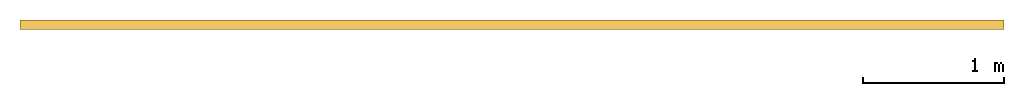
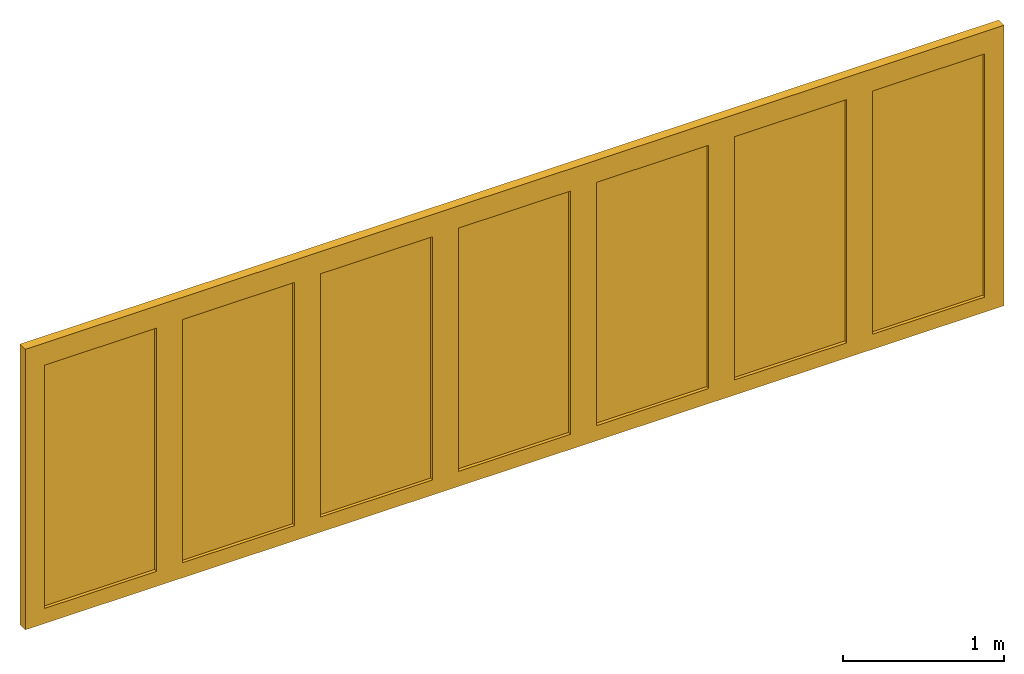
# One storey: 1 door.
"""IFC2X3 building model written with IfcOpenShell, lengths in millimetres."""

from ifc_helpers import new_model, entity, si_unit, converted_unit, direction, frame, frame_2d, origin, origin_2d_with_axis, place, context, subcontext, project, spatial, polyline, rectangle, outline, extrude, source, transform, mapped, material, material_list, type_object, type_shapes, element, save


model = new_model("IFC2X3")

# Units and contexts
model_context = context("Model", 3, precision=1e-06, world=origin(), true_north=direction((2.0, -1.71512652170913e-15, 1.0)))
context_of_model = context(None, 3, precision=1e-06, world=origin(), true_north=direction((2.0, -1.71512652170913e-15, 1.0)))
body_context = subcontext(model_context, "Body", "Model", "MODEL_VIEW")
ifc_project = project(units=[si_unit("LENGTHUNIT", "METRE", prefix="MILLI"), si_unit("AREAUNIT", "SQUARE_METRE", prefix="MILLI"), si_unit("VOLUMEUNIT", "CUBIC_METRE", prefix="MILLI"), converted_unit("PLANEANGLEUNIT", "DEGREE", entity("IfcRatioMeasure", 0.0174532925199433), si_unit("PLANEANGLEUNIT", "RADIAN"), dimensions=[0, 0, 0, 0, 0, 0, 0]), si_unit("TIMEUNIT", "SECOND")], contexts=[model_context, context_of_model])

# Site, building, storey
site_placement = place(None, origin())
site = spatial("IfcSite", under=ifc_project, at=site_placement, CompositionType="ELEMENT")
building_placement = place(site_placement, origin())
building = spatial("IfcBuilding", under=site, at=building_placement, CompositionType="ELEMENT")
storey_placement = place(building_placement, origin())
storey = spatial("IfcBuildingStorey", under=building, at=storey_placement, Name="Ground Floor", CompositionType="ELEMENT", Elevation=0.0)

# Door
ifc_material_1 = material(Name="Glass-Blue")
ifc_material_2 = material(Name="Wd-Pine Vertical")
ifc_material_3 = material(Name="Mtl-Aluminium")
ifc_material_list = material_list([ifc_material_1, ifc_material_2, ifc_material_3])
door_style = type_object("IfcDoorStyle", ConstructionType="NOTDEFINED", OperationType="NOTDEFINED", ParameterTakesPrecedence=False, Sizeable=False)
shared_shape = source(origin(), body_context, "Body", "SweptSolid", [
    extrude(rectangle(XDim=801.3429, YDim=18.0, at=frame_2d((0.0, -1.68753899743024e-14), x_axis=(1.0, 0.0))), frame((6911.74335, 267.0, 92.9), z_axis=(0.0, 0.0, 1.0), x_axis=(-1.0, 0.0, 0.0)), (0.0, 0.0, 1.0), 1839.4),
    extrude(outline(polyline([(-493.571450000001, -1012.6), (493.57145, -1012.6), (493.57145, 1012.6), (-493.571450000001, 1012.6), (-493.571450000001, -1012.6)]), holes=[polyline([(400.671449999999, 919.7), (400.671449999999, -919.7), (-400.671450000001, -919.7), (-400.671450000001, 919.7), (400.671449999999, 919.7)])]), frame((6911.74335, 234.0, 1012.6), z_axis=(0.0, 1.0, 0.0), x_axis=(-1.0, 0.0, 0.0)), (0.0, 0.0, 1.0), 66.0),
    extrude(rectangle(XDim=801.342799999999, YDim=18.0, at=frame_2d((-5.40012479177676e-13, -1.68753899743024e-14), x_axis=(1.0, 0.0))), frame((5924.6005, 267.0, 92.9), z_axis=(0.0, 0.0, 1.0), x_axis=(-1.0, 0.0, 0.0)), (0.0, 0.0, 1.0), 1839.4),
    extrude(outline(polyline([(-493.5714, -1012.6), (493.571399999999, -1012.6), (493.571399999999, 1012.6), (-493.5714, 1012.6), (-493.5714, -1012.6)]), holes=[polyline([(400.671399999999, 919.7), (400.671399999999, -919.7), (-400.6714, -919.7), (-400.6714, 919.7), (400.671399999999, 919.7)])]), frame((5924.6005, 234.0, 1012.6), z_axis=(0.0, 1.0, 0.0), x_axis=(-1.0, 0.0, 0.0)), (0.0, 0.0, 1.0), 66.0),
    extrude(rectangle(XDim=801.34287, YDim=18.0, at=frame_2d((-2.8421709430404e-13, -1.68753899743024e-14), x_axis=(1.0, 0.0))), frame((4937.457665, 267.0, 92.9), z_axis=(0.0, 0.0, 1.0), x_axis=(-1.0, 0.0, 0.0)), (0.0, 0.0, 1.0), 1839.4),
    extrude(outline(polyline([(-493.571435, -1012.6), (493.571435000001, -1012.6), (493.571435000001, 1012.6), (-493.571435, 1012.6), (-493.571435, -1012.6)]), holes=[polyline([(400.671435000001, 919.7), (400.671435000001, -919.7), (-400.671434999999, -919.7), (-400.671434999999, 919.7), (400.671435000001, 919.7)])]), frame((4937.457665, 234.0, 1012.6), z_axis=(0.0, 1.0, 0.0), x_axis=(-1.0, 0.0, 0.0)), (0.0, 0.0, 1.0), 66.0),
    extrude(rectangle(XDim=801.34286, YDim=18.0, at=frame_2d((2.8421709430404e-13, -1.68753899743024e-14), x_axis=(1.0, 0.0))), frame((3950.3148, 267.0, 92.9), z_axis=(0.0, 0.0, 1.0), x_axis=(-1.0, 0.0, 0.0)), (0.0, 0.0, 1.0), 1839.4),
    extrude(outline(polyline([(-493.571429999999, -1012.6), (493.57143, -1012.6), (493.57143, 1012.6), (-493.571429999999, 1012.6), (-493.571429999999, -1012.6)]), holes=[polyline([(400.67143, 919.7), (400.67143, -919.7), (-400.67143, -919.7), (-400.67143, 919.7), (400.67143, 919.7)])]), frame((3950.3148, 234.0, 1012.6), z_axis=(0.0, 1.0, 0.0), x_axis=(-1.0, 0.0, 0.0)), (0.0, 0.0, 1.0), 66.0),
    extrude(rectangle(XDim=801.34287, YDim=18.0, at=frame_2d((0.0, -1.68753899743024e-14), x_axis=(1.0, 0.0))), frame((2963.171935, 267.0, 92.9), z_axis=(0.0, 0.0, 1.0), x_axis=(-1.0, 0.0, 0.0)), (0.0, 0.0, 1.0), 1839.4),
    extrude(outline(polyline([(-493.571435, -1012.6), (493.571435, -1012.6), (493.571435, 1012.6), (-493.571435, 1012.6), (-493.571435, -1012.6)]), holes=[polyline([(400.671435, 919.7), (400.671435, -919.7), (-400.671435, -919.7), (-400.671435, 919.7), (400.671435, 919.7)])]), frame((2963.171935, 234.0, 1012.6), z_axis=(0.0, 1.0, 0.0), x_axis=(-1.0, 0.0, 0.0)), (0.0, 0.0, 1.0), 66.0),
    extrude(rectangle(XDim=801.3428, YDim=18.0, at=frame_2d((1.13686837721616e-13, -1.68753899743024e-14), x_axis=(1.0, 0.0))), frame((1976.0291, 267.0, 92.9), z_axis=(0.0, 0.0, 1.0), x_axis=(-1.0, 0.0, 0.0)), (0.0, 0.0, 1.0), 1839.4),
    extrude(outline(polyline([(-493.5714, -1012.6), (493.5714, -1012.6), (493.5714, 1012.6), (-493.5714, 1012.6), (-493.5714, -1012.6)]), holes=[polyline([(400.6714, 919.7), (400.6714, -919.7), (-400.6714, -919.7), (-400.6714, 919.7), (400.6714, 919.7)])]), frame((1976.0291, 234.0, 1012.6), z_axis=(0.0, 1.0, 0.0), x_axis=(-1.0, 0.0, 0.0)), (0.0, 0.0, 1.0), 66.0),
    extrude(rectangle(XDim=801.3429, YDim=18.0, at=frame_2d((0.0, -1.68753899743024e-14), x_axis=(1.0, 0.0))), frame((988.88625, 267.0, 92.9), z_axis=(0.0, 0.0, 1.0), x_axis=(-1.0, 0.0, 0.0)), (0.0, 0.0, 1.0), 1839.4),
    extrude(outline(polyline([(-493.57145, -1012.6), (493.57145, -1012.6), (493.57145, 1012.6), (-493.57145, 1012.6), (-493.57145, -1012.6)]), holes=[polyline([(400.67145, 919.7), (400.67145, -919.7), (-400.67145, -919.7), (-400.67145, 919.7), (400.67145, 919.7)])]), frame((988.88625, 234.0, 1012.6), z_axis=(0.0, 1.0, 0.0), x_axis=(-1.0, 0.0, 0.0)), (0.0, 0.0, 1.0), 66.0),
    extrude(rectangle(XDim=45.0, YDim=33.0, at=frame_2d((3.37507799486048e-14, 0.0), x_axis=(1.0, 0.0))), frame((472.8148, 250.5, 0.0), z_axis=(0.0, 0.0, 1.0), x_axis=(-1.0, 0.0, 0.0)), (0.0, 0.0, 1.0), 2025.2),
    extrude(rectangle(XDim=45.0, YDim=33.0, at=frame_2d((3.37507799486048e-14, -3.37507799486048e-14), x_axis=(1.0, 0.0))), frame((472.8148, 283.5, 0.0), z_axis=(0.0, 0.0, 1.0), x_axis=(-1.0, 0.0, 0.0)), (0.0, 0.0, 1.0), 2025.2),
    extrude(rectangle(XDim=44.9999999999995, YDim=33.0, at=frame_2d((-5.41788836017076e-13, 0.0), x_axis=(1.0, 0.0))), frame((7427.8148, 250.5, 0.0), z_axis=(0.0, 0.0, 1.0), x_axis=(-1.0, 0.0, 0.0)), (0.0, 0.0, 1.0), 2025.2),
    extrude(rectangle(XDim=44.9999999999995, YDim=33.0, at=frame_2d((-5.41788836017076e-13, -3.37507799486048e-14), x_axis=(1.0, 0.0))), frame((7427.8148, 283.5, 0.0), z_axis=(0.0, 0.0, 1.0), x_axis=(-1.0, 0.0, 0.0)), (0.0, 0.0, 1.0), 2025.2),
    extrude(rectangle(XDim=7000.0, YDim=33.0, at=origin_2d_with_axis()), frame((3950.3148, 250.5, 2025.2), z_axis=(0.0, 0.0, 1.0), x_axis=(-1.0, 0.0, 0.0)), (0.0, 0.0, 1.0), 74.8000000000001),
    extrude(rectangle(XDim=7000.0, YDim=33.0, at=frame_2d((0.0, -3.37507799486048e-14), x_axis=(1.0, 0.0))), frame((3950.3148, 283.5, 2025.2), z_axis=(0.0, 0.0, 1.0), x_axis=(-1.0, 0.0, 0.0)), (0.0, 0.0, 1.0), 74.8000000000001),
    extrude(rectangle(XDim=7000.0, YDim=33.0, at=origin_2d_with_axis()), frame((3950.3148, 250.5, -21.1), z_axis=(0.0, 0.0, 1.0), x_axis=(-1.0, 0.0, 0.0)), (0.0, 0.0, 1.0), 21.1),
    extrude(rectangle(XDim=7000.0, YDim=33.0, at=frame_2d((0.0, -3.37507799486048e-14), x_axis=(1.0, 0.0))), frame((3950.3148, 283.5, -21.1), z_axis=(0.0, 0.0, 1.0), x_axis=(-1.0, 0.0, 0.0)), (0.0, 0.0, 1.0), 21.1),
])
type_shapes(door_style, [shared_shape])
door_placement = place(storey_placement, origin())
element("IfcDoor", 1, at=door_placement, inside=storey, type_object=door_style, material=ifc_material_list, OverallHeight=2121.1, OverallWidth=7000.0, context=body_context, shape_type="MappedRepresentation", body=[
    mapped(shared_shape, transform((0.0, 0.0, 0.0), scale=1.0)),
])

save(model, "model.ifc")
